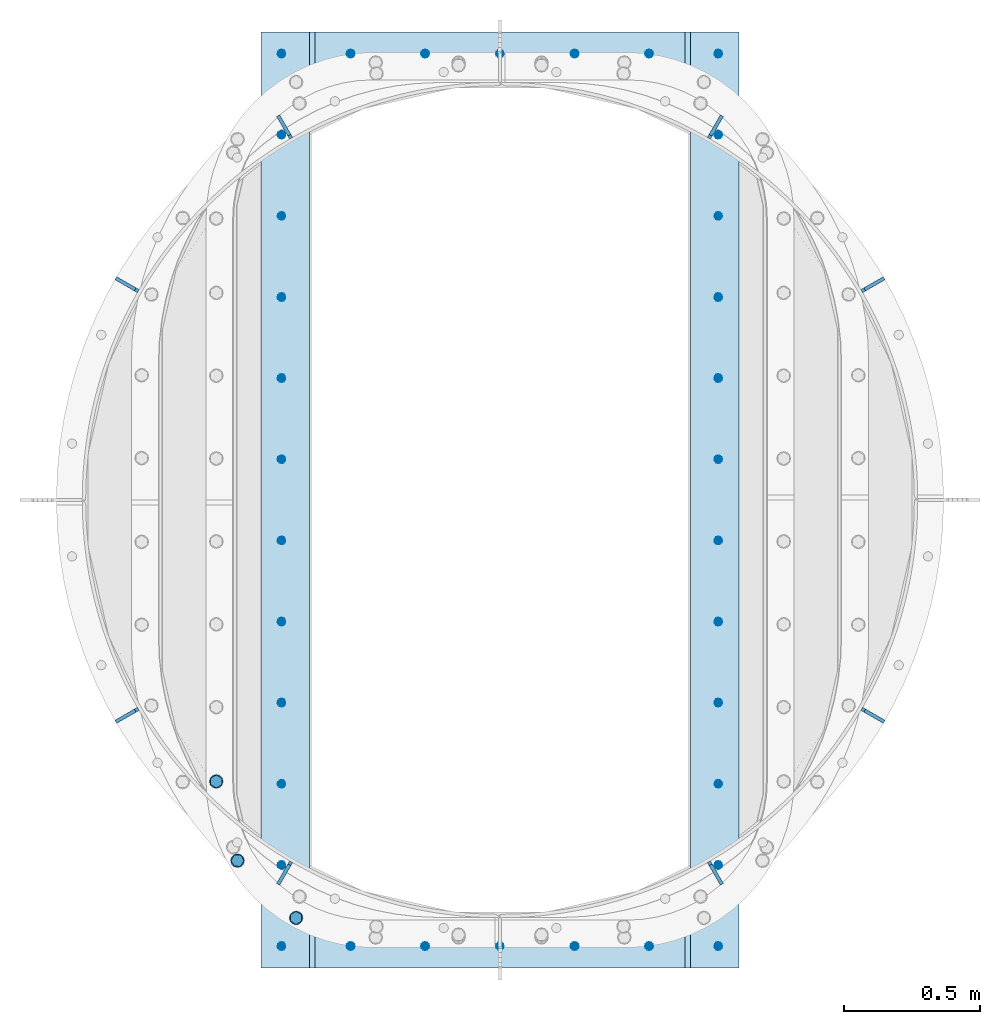
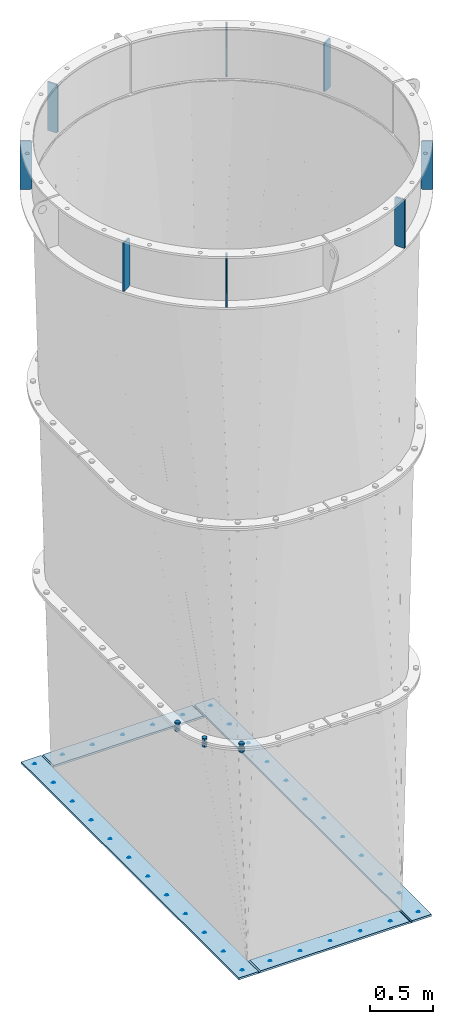
# One storey, part 1 of 15: 12 plates, 7 mechanical fasteners, 2 elements without a shape of their own.
"""IFC2X3 building model written with IfcOpenShell, lengths in millimetres."""

from ifc_helpers import new_model, si_unit, frame, origin_with_axes, place, context, subcontext, project, spatial, faceted_brep, source, transform, mapped, material, type_object, element, aggregate, save


model = new_model("IFC2X3")

# Units and contexts
model_context = context("Model", 3, precision=1e-05, world=origin_with_axes())
body_context = subcontext(model_context, "Body", "Model", "MODEL_VIEW")
ifc_project = project(units=[si_unit("LENGTHUNIT", "METRE", prefix="MILLI"), si_unit("AREAUNIT", "SQUARE_METRE"), si_unit("VOLUMEUNIT", "CUBIC_METRE"), si_unit("MASSUNIT", "GRAM", prefix="KILO"), si_unit("TIMEUNIT", "SECOND"), si_unit("PLANEANGLEUNIT", "RADIAN"), si_unit("SOLIDANGLEUNIT", "STERADIAN"), si_unit("THERMODYNAMICTEMPERATUREUNIT", "DEGREE_CELSIUS"), si_unit("LUMINOUSINTENSITYUNIT", "LUMEN")], contexts=[model_context])

# Site, building, storey
site_placement = place(None, origin_with_axes())
site = spatial("IfcSite", under=ifc_project, at=site_placement, CompositionType="ELEMENT")
building_placement = place(site_placement, origin_with_axes())
building = spatial("IfcBuilding", under=site, at=building_placement, Name="Undefined", CompositionType="ELEMENT")
storey_placement = place(building_placement, origin_with_axes())
storey = spatial("IfcBuildingStorey", under=building, at=storey_placement, Name="Undefined", CompositionType="ELEMENT", Elevation=0.0)

# Assembly, plates
assembly_1_placement = place(storey_placement, origin_with_axes())
assembly_1 = element("IfcElementAssembly", 1, at=assembly_1_placement, inside=storey, Name="TRANSITION", AssemblyPlace="NOTDEFINED", PredefinedType="RIGID_FRAME")
ifc_material_1 = material(Name="STEEL/A36")
plate_type_1 = type_object("IfcPlateType", PredefinedType="NOTDEFINED")
plate_1_placement = place(assembly_1_placement, frame((179.386981201172, 3441.70004882812, 9.52000000000007), z_axis=(0.0, -1.0, 0.0), x_axis=(-1.0, 0.0, 0.0)))
plate_1 = element("IfcPlate", 2, at=plate_1_placement, type_object=plate_type_1, material=ifc_material_1, Name="PLATE", context=body_context, shape_type="Brep", body=[
    faceted_brep([(0.0, -9.52499999999964, 0.0), (0.0, -9.525, 3441.69995117188), (0.0, 9.525, 3441.69995117188), (0.0, 9.52499999999964, 0.0), (179.386993408203, -9.525, 3441.69995117188), (179.386993408203, 9.525, 3441.69995117188), (179.386978149414, -9.525, 0.0), (179.386978149414, 9.525, 0.0)], [[[0, 1, 2, 3]], [[1, 4, 5, 2]], [[4, 6, 7, 5]], [[6, 0, 3, 7]], [[5, 7, 3, 2]], [[6, 4, 1, 0]]]),
])
plate_2_placement = place(assembly_1_placement, frame((1758.95, 3441.7, 9.52000000000007), z_axis=(0.0, -1.0, 0.0), x_axis=(-1.0, 0.0, 0.0)))
plate_2 = element("IfcPlate", 3, at=plate_2_placement, type_object=plate_type_1, material=ifc_material_1, Name="PLATE", context=body_context, shape_type="Brep", body=[
    faceted_brep([(0.0, -9.52499999999964, 0.0), (0.0, -9.525, 3441.69995117188), (0.0, 9.525, 3441.69995117188), (0.0, 9.52499999999964, 0.0), (179.386993408203, -9.525, 3441.69995117188), (179.386993408203, 9.525, 3441.69995117188), (179.386978149414, -9.525, 0.0), (179.386978149414, 9.525, 0.0)], [[[0, 1, 2, 3]], [[1, 4, 5, 2]], [[4, 6, 7, 5]], [[6, 0, 3, 7]], [[5, 7, 3, 2]], [[6, 4, 1, 0]]]),
])
plate_type_2 = type_object("IfcPlateType", PredefinedType="NOTDEFINED")
plate_3_placement = place(assembly_1_placement, frame((179.386981201172, 173.03755493164, 9.52000000000007), z_axis=(1.0, 0.0, 0.0), x_axis=(0.0, -1.0, 0.0)))
plate_3 = element("IfcPlate", 4, at=plate_3_placement, type_object=plate_type_2, material=ifc_material_1, Name="PLATE", context=body_context, shape_type="Brep", body=[
    faceted_brep([(173.037506103516, 9.52499923706055, 1400.17602539062), (0.0, 9.525, 1400.17602539062), (0.0, -9.525, 1381.12602615356), (173.037506103516, -9.525, 1381.12602615356), (173.037506103516, -9.525, 19.0499992370605), (0.0, -9.525, 19.0499992370605), (0.0, 9.52499999999964, 0.0), (173.037506103516, 9.525, 0.0)], [[[0, 1, 2, 3]], [[4, 5, 6, 7]], [[4, 7, 0, 3]], [[5, 4, 3, 2]], [[6, 5, 2, 1]], [[7, 6, 1, 0]]]),
])
plate_4_placement = place(assembly_1_placement, frame((179.386981201172, 3441.70004882812, 9.52000000000007), z_axis=(1.0, 0.0, 0.0), x_axis=(0.0, -1.0, 0.0)))
plate_4 = element("IfcPlate", 5, at=plate_4_placement, type_object=plate_type_2, material=ifc_material_1, Name="PLATE", context=body_context, shape_type="Brep", body=[
    faceted_brep([(173.037506103516, 9.52499923706055, 1400.17602539062), (0.0, 9.525, 1400.17602539062), (0.0, -9.525, 1381.12602615356), (173.037506103516, -9.525, 1381.12602615356), (173.037506103516, -9.525, 19.0499992370605), (0.0, -9.525, 19.0499992370605), (0.0, 9.52499999999964, 0.0), (173.037506103516, 9.525, 0.0)], [[[0, 1, 2, 3]], [[4, 5, 6, 7]], [[4, 7, 0, 3]], [[5, 4, 3, 2]], [[6, 5, 2, 1]], [[7, 6, 1, 0]]]),
])

assembly_2_placement = place(storey_placement, origin_with_axes())
assembly_2 = element("IfcElementAssembly", 6, at=assembly_2_placement, inside=storey, Name="TRANSITION", AssemblyPlace="NOTDEFINED", PredefinedType="RIGID_FRAME")
plate_type_3 = type_object("IfcPlateType", PredefinedType="NOTDEFINED")
plate_5_placement = place(assembly_2_placement, frame((111.125000000055, 3051.67123799589, 6283.325), z_axis=(-0.499999999906659, 0.866025403838329, 0.0), x_axis=(0.0, 0.0, 1.0)))
plate_5 = element("IfcPlate", 7, at=plate_5_placement, type_object=plate_type_3, material=ifc_material_1, Name="PLATE", context=body_context, shape_type="Brep", body=[
    faceted_brep([(0.0, -6.35000000000127, 12.6999998092629), (1.81898940354586e-12, -6.34999999999991, 95.25), (1.81898940354586e-12, 6.34999999999991, 95.25), (0.0, 6.34999999999945, 12.6999998092647), (469.899993896484, -6.35000000000719, 95.2499999999882), (469.899993896484, 6.34999999999377, 95.2499999999895), (469.899993896484, -6.35000000000127, 12.6999998092647), (469.899993896484, 6.34999999999945, 12.6999998092656), (457.199994087219, -6.35000000000036, 9.09494701772928e-13), (457.199994087219, 6.35000000000014, 2.27373675443232e-12), (12.6999998092651, -6.35000000000059, -4.54747350886464e-13), (12.6999998092651, 6.35000000000036, 9.09494701772928e-13)], [[[0, 1, 2, 3]], [[1, 4, 5, 2]], [[4, 6, 7, 5]], [[6, 8, 9, 7]], [[8, 10, 11, 9]], [[10, 0, 3, 11]], [[5, 7, 9, 11, 3, 2]], [[10, 8, 6, 4, 1, 0]]]),
])
plate_6_placement = place(assembly_2_placement, frame((-451.346237995669, 2489.20000000032, 6283.325), z_axis=(-0.866025403838329, 0.499999999906659, 0.0), x_axis=(0.0, 0.0, 1.0)))
plate_6 = element("IfcPlate", 8, at=plate_6_placement, type_object=plate_type_3, material=ifc_material_1, Name="PLATE", context=body_context, shape_type="Brep", body=[
    faceted_brep([(0.0, -6.35000000000127, 12.6999998092629), (1.81898940354586e-12, -6.34999999999991, 95.25), (1.81898940354586e-12, 6.34999999999991, 95.25), (0.0, 6.34999999999945, 12.6999998092647), (469.899993896484, -6.35000000000719, 95.2499999999882), (469.899993896484, 6.34999999999377, 95.2499999999895), (469.899993896484, -6.35000000000127, 12.6999998092647), (469.899993896484, 6.34999999999945, 12.6999998092656), (457.199994087219, -6.35000000000036, 9.09494701772928e-13), (457.199994087219, 6.35000000000014, 2.27373675443232e-12), (12.6999998092651, -6.35000000000059, -4.54747350886464e-13), (12.6999998092651, 6.35000000000036, 9.09494701772928e-13)], [[[0, 1, 2, 3]], [[1, 4, 5, 2]], [[4, 6, 7, 5]], [[6, 8, 9, 7]], [[8, 10, 11, 9]], [[10, 0, 3, 11]], [[5, 7, 9, 11, 3, 2]], [[10, 8, 6, 4, 1, 0]]]),
])
plate_7_placement = place(assembly_2_placement, frame((-451.346237995889, 952.500000000055, 6283.33), z_axis=(-0.866025403838329, -0.499999999906659, 0.0), x_axis=(0.0, 0.0, 1.0)))
plate_7 = element("IfcPlate", 9, at=plate_7_placement, type_object=plate_type_3, material=ifc_material_1, Name="PLATE", context=body_context, shape_type="Brep", body=[
    faceted_brep([(0.0, -6.35000000000127, 12.6999998092629), (1.81898940354586e-12, -6.34999999999991, 95.25), (1.81898940354586e-12, 6.34999999999991, 95.25), (0.0, 6.34999999999945, 12.6999998092647), (469.899993896484, -6.35000000000719, 95.2499999999882), (469.899993896484, 6.34999999999377, 95.2499999999895), (469.899993896484, -6.35000000000127, 12.6999998092647), (469.899993896484, 6.34999999999945, 12.6999998092656), (457.199994087219, -6.35000000000036, 9.09494701772928e-13), (457.199994087219, 6.35000000000014, 2.27373675443232e-12), (12.6999998092651, -6.35000000000059, -4.54747350886464e-13), (12.6999998092651, 6.35000000000036, 9.09494701772928e-13)], [[[0, 1, 2, 3]], [[1, 4, 5, 2]], [[4, 6, 7, 5]], [[6, 8, 9, 7]], [[8, 10, 11, 9]], [[10, 0, 3, 11]], [[5, 7, 9, 11, 3, 2]], [[10, 8, 6, 4, 1, 0]]]),
])
plate_8_placement = place(assembly_2_placement, frame((111.124999999676, 390.028762004331, 6283.33), z_axis=(-0.499999999906659, -0.866025403838329, 0.0), x_axis=(0.0, 0.0, 1.0)))
plate_8 = element("IfcPlate", 10, at=plate_8_placement, type_object=plate_type_3, material=ifc_material_1, Name="PLATE", context=body_context, shape_type="Brep", body=[
    faceted_brep([(0.0, -6.35000000000127, 12.6999998092629), (1.81898940354586e-12, -6.34999999999991, 95.25), (1.81898940354586e-12, 6.34999999999991, 95.25), (0.0, 6.34999999999945, 12.6999998092647), (469.899993896484, -6.35000000000719, 95.2499999999882), (469.899993896484, 6.34999999999377, 95.2499999999895), (469.899993896484, -6.35000000000127, 12.6999998092647), (469.899993896484, 6.34999999999945, 12.6999998092656), (457.199994087219, -6.35000000000036, 9.09494701772928e-13), (457.199994087219, 6.35000000000014, 2.27373675443232e-12), (12.6999998092651, -6.35000000000059, -4.54747350886464e-13), (12.6999998092651, 6.35000000000036, 9.09494701772928e-13)], [[[0, 1, 2, 3]], [[1, 4, 5, 2]], [[4, 6, 7, 5]], [[6, 8, 9, 7]], [[8, 10, 11, 9]], [[10, 0, 3, 11]], [[5, 7, 9, 11, 3, 2]], [[10, 8, 6, 4, 1, 0]]]),
])
plate_9_placement = place(assembly_2_placement, frame((1647.82499999994, 390.028762004111, 6283.33), z_axis=(0.499999999906659, -0.866025403838329, 0.0), x_axis=(0.0, 0.0, 1.0)))
plate_9 = element("IfcPlate", 11, at=plate_9_placement, type_object=plate_type_3, material=ifc_material_1, Name="PLATE", context=body_context, shape_type="Brep", body=[
    faceted_brep([(0.0, -6.35000000000127, 12.6999998092629), (1.81898940354586e-12, -6.34999999999991, 95.25), (1.81898940354586e-12, 6.34999999999991, 95.25), (0.0, 6.34999999999945, 12.6999998092647), (469.899993896484, -6.35000000000719, 95.2499999999882), (469.899993896484, 6.34999999999377, 95.2499999999895), (469.899993896484, -6.35000000000127, 12.6999998092647), (469.899993896484, 6.34999999999945, 12.6999998092656), (457.199994087219, -6.35000000000036, 9.09494701772928e-13), (457.199994087219, 6.35000000000014, 2.27373675443232e-12), (12.6999998092651, -6.35000000000059, -4.54747350886464e-13), (12.6999998092651, 6.35000000000036, 9.09494701772928e-13)], [[[0, 1, 2, 3]], [[1, 4, 5, 2]], [[4, 6, 7, 5]], [[6, 8, 9, 7]], [[8, 10, 11, 9]], [[10, 0, 3, 11]], [[5, 7, 9, 11, 3, 2]], [[10, 8, 6, 4, 1, 0]]]),
])
plate_10_placement = place(assembly_2_placement, frame((2210.29623799567, 952.499999999676, 6283.33), z_axis=(0.866025403838329, -0.499999999906659, 0.0), x_axis=(0.0, 0.0, 1.0)))
plate_10 = element("IfcPlate", 12, at=plate_10_placement, type_object=plate_type_3, material=ifc_material_1, Name="PLATE", context=body_context, shape_type="Brep", body=[
    faceted_brep([(0.0, -6.35000000000127, 12.6999998092629), (1.81898940354586e-12, -6.34999999999991, 95.25), (1.81898940354586e-12, 6.34999999999991, 95.25), (0.0, 6.34999999999945, 12.6999998092647), (469.899993896484, -6.35000000000719, 95.2499999999882), (469.899993896484, 6.34999999999377, 95.2499999999895), (469.899993896484, -6.35000000000127, 12.6999998092647), (469.899993896484, 6.34999999999945, 12.6999998092656), (457.199994087219, -6.35000000000036, 9.09494701772928e-13), (457.199994087219, 6.35000000000014, 2.27373675443232e-12), (12.6999998092651, -6.35000000000059, -4.54747350886464e-13), (12.6999998092651, 6.35000000000036, 9.09494701772928e-13)], [[[0, 1, 2, 3]], [[1, 4, 5, 2]], [[4, 6, 7, 5]], [[6, 8, 9, 7]], [[8, 10, 11, 9]], [[10, 0, 3, 11]], [[5, 7, 9, 11, 3, 2]], [[10, 8, 6, 4, 1, 0]]]),
])
plate_11_placement = place(assembly_2_placement, frame((2210.29623799589, 2489.19999999994, 6283.325), z_axis=(0.866025403838329, 0.499999999906659, 0.0), x_axis=(0.0, 0.0, 1.0)))
plate_11 = element("IfcPlate", 13, at=plate_11_placement, type_object=plate_type_3, material=ifc_material_1, Name="PLATE", context=body_context, shape_type="Brep", body=[
    faceted_brep([(0.0, -6.35000000000127, 12.6999998092629), (1.81898940354586e-12, -6.34999999999991, 95.25), (1.81898940354586e-12, 6.34999999999991, 95.25), (0.0, 6.34999999999945, 12.6999998092647), (469.899993896484, -6.35000000000719, 95.2499999999882), (469.899993896484, 6.34999999999377, 95.2499999999895), (469.899993896484, -6.35000000000127, 12.6999998092647), (469.899993896484, 6.34999999999945, 12.6999998092656), (457.199994087219, -6.35000000000036, 9.09494701772928e-13), (457.199994087219, 6.35000000000014, 2.27373675443232e-12), (12.6999998092651, -6.35000000000059, -4.54747350886464e-13), (12.6999998092651, 6.35000000000036, 9.09494701772928e-13)], [[[0, 1, 2, 3]], [[1, 4, 5, 2]], [[4, 6, 7, 5]], [[6, 8, 9, 7]], [[8, 10, 11, 9]], [[10, 0, 3, 11]], [[5, 7, 9, 11, 3, 2]], [[10, 8, 6, 4, 1, 0]]]),
])
plate_12_placement = place(assembly_2_placement, frame((1647.82500000032, 3051.67123799567, 6283.325), z_axis=(0.49999999990666, 0.866025403838329, 0.0), x_axis=(0.0, 0.0, 1.0)))
plate_12 = element("IfcPlate", 14, at=plate_12_placement, type_object=plate_type_3, material=ifc_material_1, Name="PLATE", context=body_context, shape_type="Brep", body=[
    faceted_brep([(0.0, -6.35000000000127, 12.6999998092629), (1.81898940354586e-12, -6.34999999999991, 95.25), (1.81898940354586e-12, 6.34999999999991, 95.25), (0.0, 6.34999999999945, 12.6999998092647), (469.899993896484, -6.35000000000719, 95.2499999999882), (469.899993896484, 6.34999999999377, 95.2499999999895), (469.899993896484, -6.35000000000127, 12.6999998092647), (469.899993896484, 6.34999999999945, 12.6999998092656), (457.199994087219, -6.35000000000036, 9.09494701772928e-13), (457.199994087219, 6.35000000000014, 2.27373675443232e-12), (12.6999998092651, -6.35000000000059, -4.54747350886464e-13), (12.6999998092651, 6.35000000000036, 9.09494701772928e-13)], [[[0, 1, 2, 3]], [[1, 4, 5, 2]], [[4, 6, 7, 5]], [[6, 8, 9, 7]], [[8, 10, 11, 9]], [[10, 0, 3, 11]], [[5, 7, 9, 11, 3, 2]], [[10, 8, 6, 4, 1, 0]]]),
])
aggregate(assembly_2, [plate_5, plate_6, plate_7, plate_8, plate_9, plate_10, plate_11, plate_12])

# Mechanical fastener
ifc_material_2 = material(Name="Undefined")
mechanical_fastener_type = type_object("IfcMechanicalFastenerType", Name="Bolt assembly")
shared_shape_1 = source(origin_with_axes(), body_context, "Body", "Brep", [
    faceted_brep([(23.8301332417684, -41.5429168574027, 0.0), (11.9150666208842, -41.5429168574027, 20.6375007629395), (-11.9150666208842, -41.5429168574027, 20.6375007629395), (-23.8301332417684, -41.5429168574027, 2.91834963977866e-15), (-11.9150666208842, -41.5429168574027, -20.6375007629394), (11.9150666208842, -41.5429168574027, -20.6375007629395), (11.9150666208842, -26.4616666666679, -20.6375007629395), (-11.9150666208842, -26.4616666666679, -20.6375007629394), (-23.8301332417684, -26.4616666666679, 2.91834963977866e-15), (-11.9150666208842, -26.4616666666679, 20.6375007629395), (11.9150666208842, -26.4616666666679, 20.6375007629395), (23.8301332417684, -26.4616666666679, 0.0), (12.6999998092651, -26.4616666666679, 0.0), (10.9985224628809, -26.4616666666679, 6.34999990463295), (6.34999990463181, -26.4616666666679, 10.9985224628816), (-1.31614667686587e-12, -26.4616666666679, 12.6999998092651), (-6.34999990463409, -26.4616666666679, 10.9985224628803), (-10.9985224628822, -26.4616666666679, 6.34999990463067), (-12.6999998092651, -26.4616666666679, -2.63229335373174e-12), (-10.9985224628796, -26.4616666666679, -6.34999990463522), (-6.34999990462954, -26.4616666666679, -10.9985224628829), (3.93434019839663e-12, -26.4616666666679, -12.6999998092651), (6.34999990463636, -26.4616666666679, -10.9985224628789), (10.9985224628835, -26.4616666666679, -6.34999990462839), (10.9985224628835, 49.7383302815743, -6.34999990462839), (6.34999990463636, 49.7383302815743, -10.9985224628789), (3.93434019839663e-12, 49.7383302815743, -12.6999998092651), (-6.34999990462954, 49.7383302815743, -10.9985224628829), (-10.9985224628796, 49.7383302815743, -6.34999990463522), (-12.6999998092651, 49.7383302815743, -2.63229335373174e-12), (-10.9985224628822, 49.7383302815743, 6.34999990463067), (-6.34999990463409, 49.7383302815743, 10.9985224628803), (-1.31614667686587e-12, 49.7383302815743, 12.6999998092651), (6.34999990463181, 49.7383302815743, 10.9985224628816), (10.9985224628809, 49.7383302815743, 6.34999990463295), (12.6999998092651, 49.7383302815743, 0.0), (25.3999996185303, 11.6383333333323, 0.0), (21.9970449257618, 11.6383333333323, 12.6999998092659), (12.6999998092636, 11.6383333333323, 21.9970449257631), (-2.63229335373174e-12, 11.6383333333323, 25.3999996185303), (-12.6999998092682, 11.6383333333323, 21.9970449257605), (-21.9970449257645, 11.6383333333323, 12.6999998092613), (-25.3999996185303, 11.6383333333323, -5.26458670746348e-12), (-21.9970449257592, 11.6383333333323, -12.6999998092704), (-12.6999998092591, 11.6383333333323, -21.9970449257658), (7.86868039679326e-12, 11.6383333333323, -25.3999996185303), (12.6999998092727, 11.6383333333323, -21.9970449257579), (21.9970449257671, 11.6383333333323, -12.6999998092568), (21.9970449257671, 15.0117733605693, -12.6999998092568), (12.6999998092727, 15.0117733605693, -21.9970449257579), (7.86868039679326e-12, 15.0117733605693, -25.3999996185303), (-12.6999998092591, 15.0117733605693, -21.9970449257658), (-21.9970449257592, 15.0117733605693, -12.6999998092704), (-25.3999996185303, 15.0117733605693, -5.26458670746348e-12), (-21.9970449257645, 15.0117733605693, 12.6999998092613), (-12.6999998092682, 15.0117733605693, 21.9970449257605), (-2.63229335373174e-12, 15.0117733605693, 25.3999996185303), (12.6999998092636, 15.0117733605693, 21.9970449257631), (21.9970449257618, 15.0117733605693, 12.6999998092659), (25.3999996185303, 15.0117733605693, 0.0), (23.8301332417684, 15.0117733605693, 0.0), (11.9150666208842, 15.0117733605693, 20.6375007629395), (-11.9150666208842, 15.0117733605693, 20.6375007629395), (-23.8301332417684, 15.0117733605693, 2.91834963977866e-15), (-11.9150666208842, 15.0117733605693, -20.6375007629394), (11.9150666208842, 15.0117733605693, -20.6375007629395), (11.9150666208842, 40.4117729790995, -20.6375007629395), (-11.9150666208842, 40.4117729790995, -20.6375007629394), (-23.8301332417684, 40.4117729790995, 2.91834963977866e-15), (-11.9150666208842, 40.4117729790995, 20.6375007629395), (11.9150666208842, 40.4117729790995, 20.6375007629395), (23.8301332417684, 40.4117729790995, 0.0)], [[[0, 1, 2, 3, 4, 5]], [[6, 7, 8, 9, 10, 11]], [[0, 11, 10, 1]], [[1, 10, 9, 2]], [[2, 9, 8, 3]], [[3, 8, 7, 4]], [[4, 7, 6, 5]], [[5, 6, 11, 0]], [[12, 13, 14, 15, 16, 17, 18, 19, 20, 21, 22, 23]], [[24, 25, 26, 27, 28, 29, 30, 31, 32, 33, 34, 35]], [[12, 35, 34, 13]], [[13, 34, 33, 14]], [[14, 33, 32, 15]], [[15, 32, 31, 16]], [[16, 31, 30, 17]], [[17, 30, 29, 18]], [[18, 29, 28, 19]], [[19, 28, 27, 20]], [[20, 27, 26, 21]], [[21, 26, 25, 22]], [[22, 25, 24, 23]], [[23, 24, 35, 12]], [[36, 37, 38, 39, 40, 41, 42, 43, 44, 45, 46, 47]], [[48, 49, 50, 51, 52, 53, 54, 55, 56, 57, 58, 59]], [[36, 59, 58, 37]], [[37, 58, 57, 38]], [[38, 57, 56, 39]], [[39, 56, 55, 40]], [[40, 55, 54, 41]], [[41, 54, 53, 42]], [[42, 53, 52, 43]], [[43, 52, 51, 44]], [[44, 51, 50, 45]], [[45, 50, 49, 46]], [[46, 49, 48, 47]], [[47, 48, 59, 36]], [[60, 61, 62, 63, 64, 65]], [[66, 67, 68, 69, 70, 71]], [[60, 71, 70, 61]], [[61, 70, 69, 62]], [[62, 69, 68, 63]], [[63, 68, 67, 64]], [[64, 67, 66, 65]], [[65, 66, 71, 60]]]),
    faceted_brep([(14.2874994277954, -26.3616666666679, 0.0), (12.3733374610262, -26.3616666666679, 7.14374971389813), (7.14374971389685, -26.3616666666679, 12.3733374610269), (-1.48066497441184e-12, -26.3616666666679, 14.2874994277954), (-7.14374971389941, -26.3616666666679, 12.3733374610255), (-12.3733374610277, -26.3616666666679, 7.14374971389557), (-14.2874994277954, -26.3616666666679, -2.96132994882368e-12), (-12.3733374610247, -26.3616666666679, -7.14374971390069), (-7.14374971389429, -26.3616666666679, -12.3733374610284), (4.42613261240646e-12, -26.3616666666679, -14.2874994277954), (7.14374971390197, -26.3616666666679, -12.373337461024), (12.3733374610292, -26.3616666666679, -7.14374971389301), (12.3733374610292, -7.31166616965666, -7.14374971389301), (7.14374971390197, -7.31166616965666, -12.373337461024), (4.42613261240646e-12, -7.31166616965666, -14.2874994277954), (-7.14374971389429, -7.31166616965666, -12.3733374610284), (-12.3733374610247, -7.31166616965666, -7.14374971390069), (-14.2874994277954, -7.31166616965666, -2.96132994882368e-12), (-12.3733374610277, -7.31166616965666, 7.14374971389557), (-7.14374971389941, -7.31166616965666, 12.3733374610255), (-1.48066497441184e-12, -7.31166616965666, 14.2874994277954), (7.14374971389685, -7.31166616965666, 12.3733374610269), (12.3733374610262, -7.31166616965666, 7.14374971389813), (14.2874994277954, -7.31166616965666, 0.0), (14.2874994277954, -7.511667242493, 0.0), (12.3733374610262, -7.511667242493, 7.14374971389813), (7.14374971389685, -7.511667242493, 12.3733374610269), (-1.48066497441184e-12, -7.511667242493, 14.2874994277954), (-7.14374971389941, -7.511667242493, 12.3733374610255), (-12.3733374610277, -7.511667242493, 7.14374971389557), (-14.2874994277954, -7.511667242493, -2.96132994882368e-12), (-12.3733374610247, -7.511667242493, -7.14374971390069), (-7.14374971389429, -7.511667242493, -12.3733374610284), (4.42613261240646e-12, -7.511667242493, -14.2874994277954), (7.14374971390197, -7.511667242493, -12.373337461024), (12.3733374610292, -7.511667242493, -7.14374971389301), (12.3733374610292, 11.6383333333323, -7.14374971389301), (7.14374971390197, 11.6383333333323, -12.373337461024), (4.42613261240646e-12, 11.6383333333323, -14.2874994277954), (-7.14374971389429, 11.6383333333323, -12.3733374610284), (-12.3733374610247, 11.6383333333323, -7.14374971390069), (-14.2874994277954, 11.6383333333323, -2.96132994882368e-12), (-12.3733374610277, 11.6383333333323, 7.14374971389557), (-7.14374971389941, 11.6383333333323, 12.3733374610255), (-1.48066497441184e-12, 11.6383333333323, 14.2874994277954), (7.14374971389685, 11.6383333333323, 12.3733374610269), (12.3733374610262, 11.6383333333323, 7.14374971389813), (14.2874994277954, 11.6383333333323, 0.0)], [[[0, 1, 2, 3, 4, 5, 6, 7, 8, 9, 10, 11]], [[12, 13, 14, 15, 16, 17, 18, 19, 20, 21, 22, 23]], [[0, 23, 22, 1]], [[1, 22, 21, 2]], [[2, 21, 20, 3]], [[3, 20, 19, 4]], [[4, 19, 18, 5]], [[5, 18, 17, 6]], [[6, 17, 16, 7]], [[7, 16, 15, 8]], [[8, 15, 14, 9]], [[9, 14, 13, 10]], [[10, 13, 12, 11]], [[11, 12, 23, 0]], [[24, 25, 26, 27, 28, 29, 30, 31, 32, 33, 34, 35]], [[36, 37, 38, 39, 40, 41, 42, 43, 44, 45, 46, 47]], [[24, 47, 46, 25]], [[25, 46, 45, 26]], [[26, 45, 44, 27]], [[27, 44, 43, 28]], [[28, 43, 42, 29]], [[29, 42, 41, 30]], [[30, 41, 40, 31]], [[31, 40, 39, 32]], [[32, 39, 38, 33]], [[33, 38, 37, 34]], [[34, 37, 36, 35]], [[35, 36, 47, 24]]]),
])
mechanical_fastener_1_placement = place(assembly_1_placement, frame((-164.119804066047, 685.590135185103, 2093.37833333333), z_axis=(-0.999433538924133, 0.0336541419974453, 0.0), x_axis=(0.0336541419974453, 0.999433538924133, 0.0)))
mechanical_fastener_1 = element("IfcMechanicalFastener", 15, at=mechanical_fastener_1_placement, type_object=mechanical_fastener_type, material=ifc_material_2, Name="Bolt assembly", NominalDiameter=25.3999996185303, NominalLength=76.1999969482422, context=body_context, shape_type="MappedRepresentation", body=[
    mapped(shared_shape_1, transform((0.0, 0.0, 0.0))),
])

mechanical_fastener_2_placement = place(assembly_1_placement, frame((-86.1266291440339, 394.377423268094, 2093.37833333333), z_axis=(-0.877026585605519, -0.480441846783901, 0.0), x_axis=(-0.480441846783901, 0.877026585605519, 0.0)))
mechanical_fastener_2 = element("IfcMechanicalFastener", 16, at=mechanical_fastener_2_placement, type_object=mechanical_fastener_type, material=ifc_material_2, Name="Bolt assembly", NominalDiameter=25.3999996185303, NominalLength=76.1999969482422, context=body_context, shape_type="MappedRepresentation", body=[
    mapped(shared_shape_1, transform((0.0, 0.0, 0.0))),
])

mechanical_fastener_3_placement = place(assembly_1_placement, frame((129.402481391864, 183.581357298915, 2093.37833333333), z_axis=(-0.509685272132189, -0.860360926223138, 0.0), x_axis=(-0.860360926223138, 0.509685272132189, 0.0)))
mechanical_fastener_3 = element("IfcMechanicalFastener", 17, at=mechanical_fastener_3_placement, type_object=mechanical_fastener_type, material=ifc_material_2, Name="Bolt assembly", NominalDiameter=25.3999996185303, NominalLength=76.1999969482422, context=body_context, shape_type="MappedRepresentation", body=[
    mapped(shared_shape_1, transform((0.0, 0.0, 0.0))),
])

shared_shape_2 = source(origin_with_axes(), body_context, "Body", "Brep", [
    faceted_brep([(14.2874994277954, -19.0450000000001, 0.0), (12.3733374610262, -19.0450000000001, 7.14374971389813), (7.14374971389685, -19.0450000000001, 12.3733374610269), (-1.48066497441184e-12, -19.0450000000001, 14.2874994277954), (-7.14374971389941, -19.0450000000001, 12.3733374610255), (-12.3733374610277, -19.0450000000001, 7.14374971389557), (-14.2874994277954, -19.0450000000001, -2.96132994882368e-12), (-12.3733374610247, -19.0450000000001, -7.14374971390069), (-7.14374971389429, -19.0450000000001, -12.3733374610284), (4.42613261240646e-12, -19.0450000000001, -14.2874994277954), (7.14374971390197, -19.0450000000001, -12.373337461024), (12.3733374610292, -19.0450000000001, -7.14374971389301), (12.3733374610292, 0.105000133897803, -7.14374971389301), (7.14374971390197, 0.105000133897803, -12.373337461024), (4.42613261240646e-12, 0.105000133897803, -14.2874994277954), (-7.14374971389429, 0.105000133897803, -12.3733374610284), (-12.3733374610247, 0.105000133897803, -7.14374971390069), (-14.2874994277954, 0.105000133897803, -2.96132994882368e-12), (-12.3733374610277, 0.105000133897803, 7.14374971389557), (-7.14374971389941, 0.105000133897803, 12.3733374610255), (-1.48066497441184e-12, 0.105000133897803, 14.2874994277954), (7.14374971389685, 0.105000133897803, 12.3733374610269), (12.3733374610262, 0.105000133897803, 7.14374971389813), (14.2874994277954, 0.105000133897803, 0.0)], [[[0, 1, 2, 3, 4, 5, 6, 7, 8, 9, 10, 11]], [[12, 13, 14, 15, 16, 17, 18, 19, 20, 21, 22, 23]], [[0, 23, 22, 1]], [[1, 22, 21, 2]], [[2, 21, 20, 3]], [[3, 20, 19, 4]], [[4, 19, 18, 5]], [[5, 18, 17, 6]], [[6, 17, 16, 7]], [[7, 16, 15, 8]], [[8, 15, 14, 9]], [[9, 14, 13, 10]], [[10, 13, 12, 11]], [[11, 12, 23, 0]]]),
])
mechanical_fastener_4_placement = place(assembly_1_placement, frame((330.2, 79.3749999999998, 0.0), z_axis=(0.0, 1.0, 0.0), x_axis=(1.0, 0.0, 0.0)))
mechanical_fastener_4 = element("IfcMechanicalFastener", 18, at=mechanical_fastener_4_placement, type_object=mechanical_fastener_type, material=ifc_material_2, Name="Bolt assembly", NominalDiameter=25.3999996185303, NominalLength=19.0499992370605, context=body_context, shape_type="MappedRepresentation", body=[
    mapped(shared_shape_2, transform((0.0, 0.0, 0.0))),
    mapped(shared_shape_2, transform((274.640014648438, 0.0, 0.0))),
    mapped(shared_shape_2, transform((549.280029296875, 0.0, 0.0))),
    mapped(shared_shape_2, transform((823.920043945312, 0.0, 0.0))),
    mapped(shared_shape_2, transform((1098.56005859375, 0.0, 0.0))),
])

mechanical_fastener_5_placement = place(assembly_1_placement, frame((330.2, 3362.325, 0.0), z_axis=(0.0, 1.0, 0.0), x_axis=(1.0, 0.0, 0.0)))
mechanical_fastener_5 = element("IfcMechanicalFastener", 19, at=mechanical_fastener_5_placement, type_object=mechanical_fastener_type, material=ifc_material_2, Name="Bolt assembly", NominalDiameter=25.3999996185303, NominalLength=19.0499992370605, context=body_context, shape_type="MappedRepresentation", body=[
    mapped(shared_shape_2, transform((0.0, 0.0, 0.0))),
    mapped(shared_shape_2, transform((274.640014648438, 0.0, 0.0))),
    mapped(shared_shape_2, transform((549.280029296875, 0.0, 0.0))),
    mapped(shared_shape_2, transform((823.920043945312, 0.0, 0.0))),
    mapped(shared_shape_2, transform((1098.56005859375, 0.0, 0.0))),
])

mechanical_fastener_6_placement = place(assembly_1_placement, frame((1682.75, 79.3749999999998, 0.0), z_axis=(-1.0, 0.0, 0.0), x_axis=(0.0, 1.0, 0.0)))
mechanical_fastener_6 = element("IfcMechanicalFastener", 20, at=mechanical_fastener_6_placement, type_object=mechanical_fastener_type, material=ifc_material_2, Name="Bolt assembly", NominalDiameter=25.3999996185303, NominalLength=19.0499992370605, context=body_context, shape_type="MappedRepresentation", body=[
    mapped(shared_shape_2, transform((0.0, 0.0, 0.0))),
    mapped(shared_shape_2, transform((298.450012207031, 0.0, 0.0))),
    mapped(shared_shape_2, transform((596.900024414062, 0.0, 0.0))),
    mapped(shared_shape_2, transform((895.350036621094, 0.0, 0.0))),
    mapped(shared_shape_2, transform((1193.80004882812, 0.0, 0.0))),
    mapped(shared_shape_2, transform((1492.25, 0.0, 0.0))),
    mapped(shared_shape_2, transform((1790.70007324219, 0.0, 0.0))),
    mapped(shared_shape_2, transform((2089.15014648438, 0.0, 0.0))),
    mapped(shared_shape_2, transform((2387.60009765625, 0.0, 0.0))),
    mapped(shared_shape_2, transform((2686.05004882812, 0.0, 0.0))),
    mapped(shared_shape_2, transform((2984.5, 0.0, 0.0))),
    mapped(shared_shape_2, transform((3282.9501953125, 0.0, 0.0))),
])

mechanical_fastener_7_placement = place(assembly_1_placement, frame((76.2, 79.3750000000001, 0.0), z_axis=(-1.0, 0.0, 0.0), x_axis=(0.0, 1.0, 0.0)))
mechanical_fastener_7 = element("IfcMechanicalFastener", 21, at=mechanical_fastener_7_placement, type_object=mechanical_fastener_type, material=ifc_material_2, Name="Bolt assembly", NominalDiameter=25.3999996185303, NominalLength=19.0499992370605, context=body_context, shape_type="MappedRepresentation", body=[
    mapped(shared_shape_2, transform((0.0, 0.0, 0.0))),
    mapped(shared_shape_2, transform((298.450012207031, 0.0, 0.0))),
    mapped(shared_shape_2, transform((596.900024414062, 0.0, 0.0))),
    mapped(shared_shape_2, transform((895.350036621094, 0.0, 0.0))),
    mapped(shared_shape_2, transform((1193.80004882812, 0.0, 0.0))),
    mapped(shared_shape_2, transform((1492.25, 0.0, 0.0))),
    mapped(shared_shape_2, transform((1790.70007324219, 0.0, 0.0))),
    mapped(shared_shape_2, transform((2089.15014648438, 0.0, 0.0))),
    mapped(shared_shape_2, transform((2387.60009765625, 0.0, 0.0))),
    mapped(shared_shape_2, transform((2686.05004882812, 0.0, 0.0))),
    mapped(shared_shape_2, transform((2984.5, 0.0, 0.0))),
    mapped(shared_shape_2, transform((3282.9501953125, 0.0, 0.0))),
])

aggregate(assembly_1, [mechanical_fastener_1, mechanical_fastener_2, mechanical_fastener_3, mechanical_fastener_4, mechanical_fastener_5, mechanical_fastener_6, mechanical_fastener_7, plate_1, plate_3, plate_2, plate_4])

save(model, "model.ifc")
